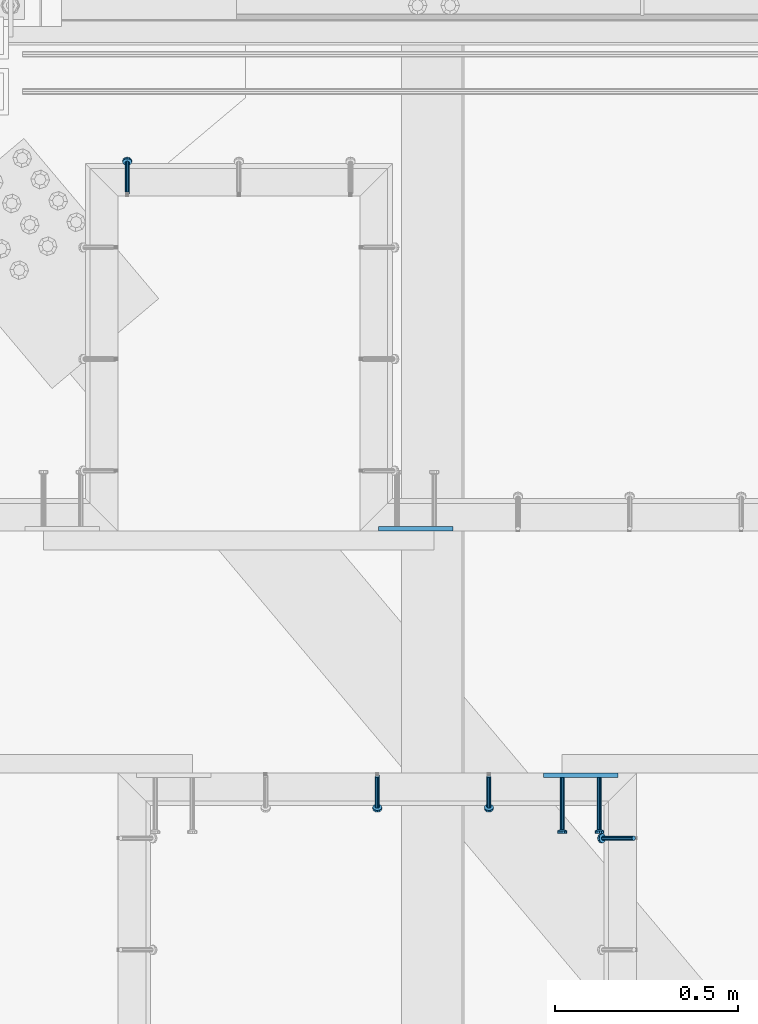
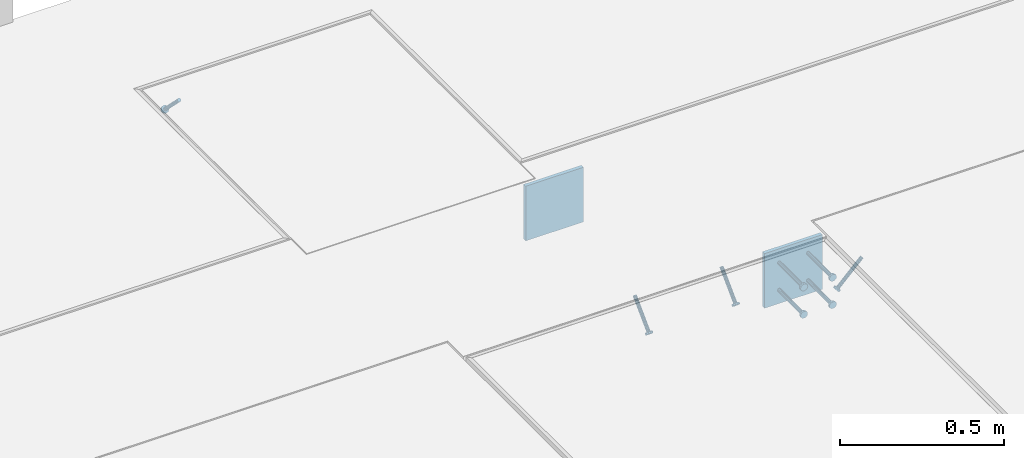
# One storey, part 2503 of 3843: 6 beams, 4 members, 5 elements without a shape of their own.
"""IFC2X3 building model written with IfcOpenShell, lengths in millimetres."""

import ifcopenshell
import ifcopenshell.guid

model = None  # the IFC model being written
_history = None  # IfcOwnerHistory: only IFC2X3 demands one
_inside = {}  # id of a spatial element -> (the spatial element, [elements in it])
_under = {}  # id of a project, library or spatial element -> (it, [spatial elements below it])
_declared = {}  # id of a project -> (the project, [libraries it declares])
_typed = {}  # id of a type object -> (the type object, [elements of that type])
_made_of = {}  # id of a material, layer set ... -> (it, [elements and type objects made of it])


def new_model(schema):
    """Start an empty IFC model of exactly this schema.

    Asked for "IFC4X3", IfcOpenShell would pick the latest addendum, in which some entities
    have other attributes; the version numbers below select the first issue.
    IFC2X3 requires an IfcOwnerHistory on every rooted entity: one is made here for all.
    """
    global model, _history
    if schema == "IFC4X3":
        model = ifcopenshell.file(schema_version=(4, 3, 0, 0))
    else:
        model = ifcopenshell.file(schema=schema)
    _inside.clear()
    _under.clear()
    _declared.clear()
    _typed.clear()
    _made_of.clear()
    _history = None
    if model.schema == "IFC2X3":
        org = make("IfcOrganization", Name="unknown")
        user = make(
            "IfcPersonAndOrganization",
            ThePerson=make("IfcPerson", FamilyName="unknown"),
            TheOrganization=org,
        )
        app = make(
            "IfcApplication",
            ApplicationDeveloper=org,
            Version="unknown",
            ApplicationFullName="unknown",
            ApplicationIdentifier="unknown",
        )
        _history = make(
            "IfcOwnerHistory",
            OwningUser=user,
            OwningApplication=app,
            ChangeAction="ADDED",
            CreationDate=0,
        )
    return model


def make(cls, **values):
    """One entity of the class cls with the attributes given. An attribute that is None is left unset."""
    return model.create_entity(
        cls, **{name: value for name, value in values.items() if value is not None}
    )


def rooted(cls, **values):
    """An entity with a GlobalId (a new one), such as an element, a storey or a relation."""
    return make(cls, GlobalId=ifcopenshell.guid.new(), OwnerHistory=_history, **values)


def si_unit(unit_type, name, prefix=None):
    """IfcSIUnit, for example si_unit("LENGTHUNIT", "METRE", prefix="MILLI")."""
    return make("IfcSIUnit", UnitType=unit_type, Prefix=prefix, Name=name)


def assignment(units):
    """IfcUnitAssignment: the units of a project."""
    return None if units is None else make("IfcUnitAssignment", Units=units)


def point(xyz):
    """IfcCartesianPoint."""
    return None if xyz is None else make("IfcCartesianPoint", Coordinates=xyz)


def direction(xyz):
    """IfcDirection."""
    return None if xyz is None else make("IfcDirection", DirectionRatios=xyz)


def frame(location, z_axis=None, x_axis=None):
    """IfcAxis2Placement3D, a coordinate frame: its origin and axes. An axis left out is left unset."""
    return make(
        "IfcAxis2Placement3D",
        Location=point(location),
        Axis=direction(z_axis),
        RefDirection=direction(x_axis),
    )


def origin_with_axes():
    """The frame at (0, 0, 0) with the z axis (0, 0, 1) and the x axis (1, 0, 0) written out."""
    return frame((0.0, 0.0, 0.0), z_axis=(0.0, 0.0, 1.0), x_axis=(1.0, 0.0, 0.0))


def place(relative_to, where):
    """IfcLocalPlacement: puts the frame where relative to a parent placement (None: the world)."""
    return make(
        "IfcLocalPlacement", PlacementRelTo=relative_to, RelativePlacement=where
    )


def context(
    kind, dimensions, precision=None, world=None, true_north=None, identifier=None
):
    """IfcGeometricRepresentationContext, for example the 3D "Model" context."""
    return make(
        "IfcGeometricRepresentationContext",
        ContextIdentifier=identifier,
        ContextType=kind,
        CoordinateSpaceDimension=dimensions,
        Precision=precision,
        WorldCoordinateSystem=world,
        TrueNorth=true_north,
    )


def subcontext(parent, identifier, kind, view, scale=None):
    """IfcGeometricRepresentationSubContext, for example "Body" below "Model"."""
    return make(
        "IfcGeometricRepresentationSubContext",
        ContextIdentifier=identifier,
        ContextType=kind,
        ParentContext=parent,
        TargetScale=scale,
        TargetView=view,
    )


def project(units=None, contexts=None):
    """IfcProject with its units and contexts."""
    return rooted(
        "IfcProject",
        Name="project",
        RepresentationContexts=contexts,
        UnitsInContext=assignment(units),
    )


def spatial(cls, under=None, at=None, **own):
    """A site, building, storey or space (cls), placed at a placement, below another one or the project."""
    s = rooted(cls, ObjectPlacement=at, **own)
    if under is not None:
        _under.setdefault(under.id(), (under, []))[1].append(s)
    return s


def faces_of(points, faces, orient=None, outer=None):
    """IfcFace entities. A face is a list of loops; a loop is a list of indices into points, from 0.

    orient and outer hold one flag for each loop. By default every Orientation is true, the
    first loop of a face is its IfcFaceOuterBound and the others are IfcFaceBound.
    """
    made = []
    for i, loops in enumerate(faces):
        bounds = []
        for j, loop in enumerate(loops):
            is_outer = j == 0 if outer is None else outer[i][j]
            bounds.append(
                make(
                    "IfcFaceOuterBound" if is_outer else "IfcFaceBound",
                    Bound=make("IfcPolyLoop", Polygon=[points[k] for k in loop]),
                    Orientation=True if orient is None else orient[i][j],
                )
            )
        made.append(make("IfcFace", Bounds=bounds))
    return made


def faceted_brep(points, faces, orient=None, outer=None, voids=None):
    """IfcFacetedBrep: a solid bounded by flat faces; with voids (closed shells), ...WithVoids."""
    shared = [point(p) for p in points]
    hull = make("IfcClosedShell", CfsFaces=faces_of(shared, faces, orient, outer))
    if voids is None:
        return make("IfcFacetedBrep", Outer=hull)
    return make(
        "IfcFacetedBrepWithVoids",
        Outer=hull,
        Voids=[
            make(cls, CfsFaces=faces_of(shared, fs, o, b)) for cls, fs, o, b in voids
        ],
    )


def shape(context_of_items, identifier, shape_type, items):
    """IfcShapeRepresentation: the items that make up one representation, for example the "Body"."""
    return make(
        "IfcShapeRepresentation",
        ContextOfItems=context_of_items,
        RepresentationIdentifier=identifier,
        RepresentationType=shape_type,
        Items=items,
    )


def material(Name=None, Category=None):
    """IfcMaterial."""
    return make("IfcMaterial", Name=Name, Category=Category)


def made_of(thing, what):
    """Note that an element or type object is made of a material, layer set ...; save() writes the relation."""
    if what is not None:
        _made_of.setdefault(what.id(), (what, []))[1].append(thing)
    return thing


def type_object(cls, material=None, **own):
    """A type object (cls), such as IfcWallType, which elements share."""
    return made_of(rooted(cls, **own), material)


def element(
    cls,
    number,
    at=None,
    inside=None,
    cuts=None,
    type_object=None,
    material=None,
    context=None,
    identifier="Body",
    shape_type=None,
    held_by="IfcProductDefinitionShape",
    body=None,
    shapes=None,
    **own,
):
    """One element of the class cls, such as IfcWall. Its Tag is "e" and its number.

    at: its placement. inside: the storey or other place that contains it. cuts: it is an
    opening in that element (IfcRelVoidsElement). A single representation is given by context,
    identifier, shape_type and body (its items); several are given by shapes. held_by: the class
    of the entity that holds the representations. save() writes the other relations.
    """
    e = rooted(cls, Tag="e%d" % number, ObjectPlacement=at, **own)
    if body is not None:
        shapes = [shape(context, identifier, shape_type, body)]
    if shapes is not None:
        e.Representation = make(held_by, Representations=shapes)
    if inside is not None:
        _inside.setdefault(inside.id(), (inside, []))[1].append(e)
    if cuts is not None:
        rooted(
            "IfcRelVoidsElement", RelatingBuildingElement=cuts, RelatedOpeningElement=e
        )
    if type_object is not None:
        _typed.setdefault(type_object.id(), (type_object, []))[1].append(e)
    return made_of(e, material)


def aggregate(whole, parts):
    """IfcRelAggregates: a whole, such as a stair, and the parts it consists of."""
    return rooted("IfcRelAggregates", RelatingObject=whole, RelatedObjects=parts)


def save(model, path):
    """Write the relations noted so far, then the file.

    IfcRelAggregates (storeys below a building ...), IfcRelContainedInSpatialStructure (elements
    in a storey), IfcRelDefinesByType, IfcRelAssociatesMaterial and IfcRelDeclares: one each for
    every whole, place, type object, material and project.
    """
    for whole, parts in _under.values():
        aggregate(whole, parts)
    for where, things in _inside.values():
        rooted(
            "IfcRelContainedInSpatialStructure",
            RelatedElements=things,
            RelatingStructure=where,
        )
    for kind, things in _typed.values():
        rooted("IfcRelDefinesByType", RelatedObjects=things, RelatingType=kind)
    for what, things in _made_of.values():
        rooted("IfcRelAssociatesMaterial", RelatedObjects=things, RelatingMaterial=what)
    for by, libraries in _declared.values():
        rooted("IfcRelDeclares", RelatingContext=by, RelatedDefinitions=libraries)
    model.write(path)


model = new_model("IFC2X3")

# Units and contexts
model_context = context("Model", 3, precision=1e-05, world=origin_with_axes())
body_context = subcontext(model_context, "Body", "Model", "MODEL_VIEW")
ifc_project = project(units=[si_unit("LENGTHUNIT", "METRE", prefix="MILLI"), si_unit("AREAUNIT", "SQUARE_METRE"), si_unit("VOLUMEUNIT", "CUBIC_METRE"), si_unit("MASSUNIT", "GRAM", prefix="KILO"), si_unit("TIMEUNIT", "SECOND"), si_unit("PLANEANGLEUNIT", "RADIAN"), si_unit("SOLIDANGLEUNIT", "STERADIAN"), si_unit("THERMODYNAMICTEMPERATUREUNIT", "DEGREE_CELSIUS"), si_unit("LUMINOUSINTENSITYUNIT", "LUMEN")], contexts=[model_context])

# Site, building, storey
site_placement = place(None, origin_with_axes())
site = spatial("IfcSite", under=ifc_project, at=site_placement, CompositionType="ELEMENT")
building_placement = place(site_placement, origin_with_axes())
building = spatial("IfcBuilding", under=site, at=building_placement, Name="Undefined", CompositionType="ELEMENT")
storey_placement = place(building_placement, origin_with_axes())
storey = spatial("IfcBuildingStorey", under=building, at=storey_placement, Name="Undefined", CompositionType="ELEMENT", Elevation=0.0)

# Assembly, member
assembly_1_placement = place(storey_placement, origin_with_axes())
assembly_1 = element("IfcElementAssembly", 1, at=assembly_1_placement, inside=storey, Name="EMBED_ANGLE", AssemblyPlace="NOTDEFINED", PredefinedType="RIGID_FRAME")
ifc_material_1 = material(Name="STEEL/A108")
member_type = type_object("IfcMemberType", PredefinedType="NOTDEFINED")
member_1_placement = place(assembly_1_placement, frame((49892.7001822153, 91631.9607012059, 30446.6625), z_axis=(-1.0, 0.0, 0.0), x_axis=(5.70000238222118e-08, 0.707106781186546, -0.707106781186546)))
member_1 = element("IfcMember", 2, at=member_1_placement, type_object=member_type, material=ifc_material_1, Name="HEADED STUD ANCHOR", context=body_context, shape_type="Brep", body=[
    faceted_brep([(7.27595761418343e-12, -3.18000006675175, 5.5), (0.0, -5.49999999998363, 3.1800000667572), (118.110000000976, -5.49999999999091, 3.1800000667572), (118.110000000983, -3.18000006675175, 5.5), (0.0, -6.3499999046162, 0.0), (118.110000000968, -6.34999990461256, 0.0), (0.0, -5.49999999998363, -3.1800000667572), (118.110000000976, -5.49999999999091, -3.1800000667572), (7.27595761418343e-12, -3.18000006675175, -5.5), (118.110000000983, -3.18000006675175, -5.5), (7.27595761418343e-12, -1.81898940354586e-12, -6.34999990463257), (118.110000000968, -1.81898940354586e-12, -6.34999990463257), (0.0, 3.18000006675175, -5.5), (118.110000000968, 3.18000006674811, -5.5), (7.27595761418343e-12, 5.49999999998363, -3.1800000667572), (118.110000000983, 5.49999999998363, -3.1800000667572), (7.27595761418343e-12, 6.3499999046162, 0.0), (118.110000000976, 6.34999990461256, 0.0), (7.27595761418343e-12, 5.49999999998363, 3.1800000667572), (118.110000000983, 5.49999999998363, 3.1800000667572), (0.0, 3.18000006675175, 5.5), (118.110000000968, 3.18000006674811, 5.5), (7.27595761418343e-12, -1.81898940354586e-12, 6.34999990463257), (118.110000000968, -1.81898940354586e-12, 6.34999990463257), (120.650000000991, -10.9899997710909, 6.34999990463257), (120.650000000998, -6.34000015257152, 10.9899997711182), (120.650000000991, -12.6999998092379, 0.0), (120.650000000991, -10.9899997710909, -6.34999990463257), (120.650000000998, -6.34000015257152, -10.9899997711182), (120.650000000991, -1.81898940354586e-12, -12.6899995803833), (120.650000000991, 6.34000015257152, -10.9899997711182), (120.650000000998, 10.9899997710909, -6.34999990463257), (120.650000000991, 12.6999998092342, 0.0), (120.650000000998, 10.9899997710909, 6.34999990463257), (120.650000000991, 6.34000015257152, 10.9899997711182), (120.650000000991, -1.81898940354586e-12, 12.6899995803833), (127.000000001048, -10.9899997710945, 6.34999990463257), (127.000000001048, -6.34000015257152, 10.9899997711182), (127.000000001048, -12.6999998092342, 0.0), (127.000000001048, -10.9899997710945, -6.34999990463257), (127.000000001048, -6.34000015257152, -10.9899997711182), (127.000000001048, 1.81898940354586e-12, -12.6899995803833), (127.000000001048, 6.34000015256788, -10.9899997711182), (127.000000001048, 10.9899997710909, -6.34999990463257), (127.000000001048, 12.6999998092379, 0.0), (127.000000001048, 10.9899997710909, 6.34999990463257), (127.000000001048, 6.34000015256788, 10.9899997711182), (127.000000001048, 1.81898940354586e-12, 12.6899995803833)], [[[0, 1, 2, 3]], [[1, 4, 5, 2]], [[4, 6, 7, 5]], [[6, 8, 9, 7]], [[8, 10, 11, 9]], [[10, 12, 13, 11]], [[12, 14, 15, 13]], [[14, 16, 17, 15]], [[16, 18, 19, 17]], [[18, 20, 21, 19]], [[20, 22, 23, 21]], [[22, 0, 3, 23]], [[22, 20, 18, 16, 14, 12, 10, 8, 6, 4, 1, 0]], [[3, 2, 24, 25]], [[2, 5, 26, 24]], [[5, 7, 27, 26]], [[7, 9, 28, 27]], [[9, 11, 29, 28]], [[11, 13, 30, 29]], [[13, 15, 31, 30]], [[15, 17, 32, 31]], [[17, 19, 33, 32]], [[19, 21, 34, 33]], [[21, 23, 35, 34]], [[23, 3, 25, 35]], [[25, 24, 36, 37]], [[24, 26, 38, 36]], [[26, 27, 39, 38]], [[27, 28, 40, 39]], [[28, 29, 41, 40]], [[29, 30, 42, 41]], [[30, 31, 43, 42]], [[31, 32, 44, 43]], [[32, 33, 45, 44]], [[33, 34, 46, 45]], [[34, 35, 47, 46]], [[35, 25, 37, 47]], [[38, 39, 40, 41, 42, 43, 44, 45, 46, 47, 37, 36]]]),
])
aggregate(assembly_1, [member_1])

# Assembly, members
assembly_2_placement = place(storey_placement, origin_with_axes())
assembly_2 = element("IfcElementAssembly", 3, at=assembly_2_placement, inside=storey, Name="EMBED_ANGLE", AssemblyPlace="NOTDEFINED", PredefinedType="RIGID_FRAME")
member_2_placement = place(assembly_2_placement, frame((50880.1503329119, 90041.285203125, 30446.6625), z_axis=(-1.0, 0.0, 0.0), x_axis=(0.0, -0.707106781186548, -0.707106781186548)))
member_2 = element("IfcMember", 4, at=member_2_placement, type_object=member_type, material=ifc_material_1, Name="HEADED STUD ANCHOR", context=body_context, shape_type="Brep", body=[
    faceted_brep([(7.27595761418343e-12, -3.18000006675175, 5.5), (0.0, -5.49999999998363, 3.1800000667572), (118.110000000976, -5.49999999999091, 3.1800000667572), (118.110000000983, -3.18000006675175, 5.5), (0.0, -6.3499999046162, 0.0), (118.110000000968, -6.34999990461256, 0.0), (0.0, -5.49999999998363, -3.1800000667572), (118.110000000976, -5.49999999999091, -3.1800000667572), (7.27595761418343e-12, -3.18000006675175, -5.5), (118.110000000983, -3.18000006675175, -5.5), (7.27595761418343e-12, -1.81898940354586e-12, -6.34999990463257), (118.110000000968, -1.81898940354586e-12, -6.34999990463257), (0.0, 3.18000006675175, -5.5), (118.110000000968, 3.18000006674811, -5.5), (7.27595761418343e-12, 5.49999999998363, -3.1800000667572), (118.110000000983, 5.49999999998363, -3.1800000667572), (7.27595761418343e-12, 6.3499999046162, 0.0), (118.110000000976, 6.34999990461256, 0.0), (7.27595761418343e-12, 5.49999999998363, 3.1800000667572), (118.110000000983, 5.49999999998363, 3.1800000667572), (0.0, 3.18000006675175, 5.5), (118.110000000968, 3.18000006674811, 5.5), (7.27595761418343e-12, -1.81898940354586e-12, 6.34999990463257), (118.110000000968, -1.81898940354586e-12, 6.34999990463257), (120.650000000991, -10.9899997710909, 6.34999990463257), (120.650000000998, -6.34000015257152, 10.9899997711182), (120.650000000991, -12.6999998092379, 0.0), (120.650000000991, -10.9899997710909, -6.34999990463257), (120.650000000998, -6.34000015257152, -10.9899997711182), (120.650000000991, -1.81898940354586e-12, -12.6899995803833), (120.650000000991, 6.34000015257152, -10.9899997711182), (120.650000000998, 10.9899997710909, -6.34999990463257), (120.650000000991, 12.6999998092342, 0.0), (120.650000000998, 10.9899997710909, 6.34999990463257), (120.650000000991, 6.34000015257152, 10.9899997711182), (120.650000000991, -1.81898940354586e-12, 12.6899995803833), (127.000000001048, -10.9899997710945, 6.34999990463257), (127.000000001048, -6.34000015257152, 10.9899997711182), (127.000000001048, -12.6999998092342, 0.0), (127.000000001048, -10.9899997710945, -6.34999990463257), (127.000000001048, -6.34000015257152, -10.9899997711182), (127.000000001048, 1.81898940354586e-12, -12.6899995803833), (127.000000001048, 6.34000015256788, -10.9899997711182), (127.000000001048, 10.9899997710909, -6.34999990463257), (127.000000001048, 12.6999998092379, 0.0), (127.000000001048, 10.9899997710909, 6.34999990463257), (127.000000001048, 6.34000015256788, 10.9899997711182), (127.000000001048, 1.81898940354586e-12, 12.6899995803833)], [[[0, 1, 2, 3]], [[1, 4, 5, 2]], [[4, 6, 7, 5]], [[6, 8, 9, 7]], [[8, 10, 11, 9]], [[10, 12, 13, 11]], [[12, 14, 15, 13]], [[14, 16, 17, 15]], [[16, 18, 19, 17]], [[18, 20, 21, 19]], [[20, 22, 23, 21]], [[22, 0, 3, 23]], [[22, 20, 18, 16, 14, 12, 10, 8, 6, 4, 1, 0]], [[3, 2, 24, 25]], [[2, 5, 26, 24]], [[5, 7, 27, 26]], [[7, 9, 28, 27]], [[9, 11, 29, 28]], [[11, 13, 30, 29]], [[13, 15, 31, 30]], [[15, 17, 32, 31]], [[17, 19, 33, 32]], [[19, 21, 34, 33]], [[21, 23, 35, 34]], [[23, 3, 25, 35]], [[25, 24, 36, 37]], [[24, 26, 38, 36]], [[26, 27, 39, 38]], [[27, 28, 40, 39]], [[28, 29, 41, 40]], [[29, 30, 42, 41]], [[30, 31, 43, 42]], [[31, 32, 44, 43]], [[32, 33, 45, 44]], [[33, 34, 46, 45]], [[34, 35, 47, 46]], [[35, 25, 37, 47]], [[38, 39, 40, 41, 42, 43, 44, 45, 46, 47, 37, 36]]]),
])
member_3_placement = place(assembly_2_placement, frame((50575.3503329119, 90041.285203125, 30446.6625), z_axis=(-1.0, 0.0, 0.0), x_axis=(0.0, -0.707106781186548, -0.707106781186548)))
member_3 = element("IfcMember", 5, at=member_3_placement, type_object=member_type, material=ifc_material_1, Name="HEADED STUD ANCHOR", context=body_context, shape_type="Brep", body=[
    faceted_brep([(7.27595761418343e-12, -3.18000006675175, 5.5), (0.0, -5.49999999998363, 3.1800000667572), (118.110000000976, -5.49999999999091, 3.1800000667572), (118.110000000983, -3.18000006675175, 5.5), (0.0, -6.3499999046162, 0.0), (118.110000000968, -6.34999990461256, 0.0), (0.0, -5.49999999998363, -3.1800000667572), (118.110000000976, -5.49999999999091, -3.1800000667572), (7.27595761418343e-12, -3.18000006675175, -5.5), (118.110000000983, -3.18000006675175, -5.5), (7.27595761418343e-12, -1.81898940354586e-12, -6.34999990463257), (118.110000000968, -1.81898940354586e-12, -6.34999990463257), (0.0, 3.18000006675175, -5.5), (118.110000000968, 3.18000006674811, -5.5), (7.27595761418343e-12, 5.49999999998363, -3.1800000667572), (118.110000000983, 5.49999999998363, -3.1800000667572), (7.27595761418343e-12, 6.3499999046162, 0.0), (118.110000000976, 6.34999990461256, 0.0), (7.27595761418343e-12, 5.49999999998363, 3.1800000667572), (118.110000000983, 5.49999999998363, 3.1800000667572), (0.0, 3.18000006675175, 5.5), (118.110000000968, 3.18000006674811, 5.5), (7.27595761418343e-12, -1.81898940354586e-12, 6.34999990463257), (118.110000000968, -1.81898940354586e-12, 6.34999990463257), (120.650000000991, -10.9899997710909, 6.34999990463257), (120.650000000998, -6.34000015257152, 10.9899997711182), (120.650000000991, -12.6999998092379, 0.0), (120.650000000991, -10.9899997710909, -6.34999990463257), (120.650000000998, -6.34000015257152, -10.9899997711182), (120.650000000991, -1.81898940354586e-12, -12.6899995803833), (120.650000000991, 6.34000015257152, -10.9899997711182), (120.650000000998, 10.9899997710909, -6.34999990463257), (120.650000000991, 12.6999998092342, 0.0), (120.650000000998, 10.9899997710909, 6.34999990463257), (120.650000000991, 6.34000015257152, 10.9899997711182), (120.650000000991, -1.81898940354586e-12, 12.6899995803833), (127.000000001048, -10.9899997710945, 6.34999990463257), (127.000000001048, -6.34000015257152, 10.9899997711182), (127.000000001048, -12.6999998092342, 0.0), (127.000000001048, -10.9899997710945, -6.34999990463257), (127.000000001048, -6.34000015257152, -10.9899997711182), (127.000000001048, 1.81898940354586e-12, -12.6899995803833), (127.000000001048, 6.34000015256788, -10.9899997711182), (127.000000001048, 10.9899997710909, -6.34999990463257), (127.000000001048, 12.6999998092379, 0.0), (127.000000001048, 10.9899997710909, 6.34999990463257), (127.000000001048, 6.34000015256788, 10.9899997711182), (127.000000001048, 1.81898940354586e-12, 12.6899995803833)], [[[0, 1, 2, 3]], [[1, 4, 5, 2]], [[4, 6, 7, 5]], [[6, 8, 9, 7]], [[8, 10, 11, 9]], [[10, 12, 13, 11]], [[12, 14, 15, 13]], [[14, 16, 17, 15]], [[16, 18, 19, 17]], [[18, 20, 21, 19]], [[20, 22, 23, 21]], [[22, 0, 3, 23]], [[22, 20, 18, 16, 14, 12, 10, 8, 6, 4, 1, 0]], [[3, 2, 24, 25]], [[2, 5, 26, 24]], [[5, 7, 27, 26]], [[7, 9, 28, 27]], [[9, 11, 29, 28]], [[11, 13, 30, 29]], [[13, 15, 31, 30]], [[15, 17, 32, 31]], [[17, 19, 33, 32]], [[19, 21, 34, 33]], [[21, 23, 35, 34]], [[23, 3, 25, 35]], [[25, 24, 36, 37]], [[24, 26, 38, 36]], [[26, 27, 39, 38]], [[27, 28, 40, 39]], [[28, 29, 41, 40]], [[29, 30, 42, 41]], [[30, 31, 43, 42]], [[31, 32, 44, 43]], [[32, 33, 45, 44]], [[33, 34, 46, 45]], [[34, 35, 47, 46]], [[35, 25, 37, 47]], [[38, 39, 40, 41, 42, 43, 44, 45, 46, 47, 37, 36]]]),
])
aggregate(assembly_2, [member_2, member_3])

# Assembly, member
assembly_3_placement = place(storey_placement, origin_with_axes())
assembly_3 = element("IfcElementAssembly", 6, at=assembly_3_placement, inside=storey, Name="EMBED_ANGLE", AssemblyPlace="NOTDEFINED", PredefinedType="RIGID_FRAME")
member_4_placement = place(assembly_3_placement, frame((51275.4879423829, 89871.4227092285, 30446.6625), z_axis=(0.0, 1.0, 0.0), x_axis=(-0.707106781186548, 0.0, -0.707106781186548)))
member_4 = element("IfcMember", 7, at=member_4_placement, type_object=member_type, material=ifc_material_1, Name="HEADED STUD ANCHOR", context=body_context, shape_type="Brep", body=[
    faceted_brep([(7.27595761418343e-12, -3.18000006675175, 5.5), (0.0, -5.49999999998363, 3.1800000667572), (118.110000000976, -5.49999999999091, 3.1800000667572), (118.110000000983, -3.18000006675175, 5.5), (0.0, -6.3499999046162, 0.0), (118.110000000968, -6.34999990461256, 0.0), (0.0, -5.49999999998363, -3.1800000667572), (118.110000000976, -5.49999999999091, -3.1800000667572), (7.27595761418343e-12, -3.18000006675175, -5.5), (118.110000000983, -3.18000006675175, -5.5), (7.27595761418343e-12, -1.81898940354586e-12, -6.34999990463257), (118.110000000968, -1.81898940354586e-12, -6.34999990463257), (0.0, 3.18000006675175, -5.5), (118.110000000968, 3.18000006674811, -5.5), (7.27595761418343e-12, 5.49999999998363, -3.1800000667572), (118.110000000983, 5.49999999998363, -3.1800000667572), (7.27595761418343e-12, 6.3499999046162, 0.0), (118.110000000976, 6.34999990461256, 0.0), (7.27595761418343e-12, 5.49999999998363, 3.1800000667572), (118.110000000983, 5.49999999998363, 3.1800000667572), (0.0, 3.18000006675175, 5.5), (118.110000000968, 3.18000006674811, 5.5), (7.27595761418343e-12, -1.81898940354586e-12, 6.34999990463257), (118.110000000968, -1.81898940354586e-12, 6.34999990463257), (120.650000000991, -10.9899997710909, 6.34999990463257), (120.650000000998, -6.34000015257152, 10.9899997711182), (120.650000000991, -12.6999998092379, 0.0), (120.650000000991, -10.9899997710909, -6.34999990463257), (120.650000000998, -6.34000015257152, -10.9899997711182), (120.650000000991, -1.81898940354586e-12, -12.6899995803833), (120.650000000991, 6.34000015257152, -10.9899997711182), (120.650000000998, 10.9899997710909, -6.34999990463257), (120.650000000991, 12.6999998092342, 0.0), (120.650000000998, 10.9899997710909, 6.34999990463257), (120.650000000991, 6.34000015257152, 10.9899997711182), (120.650000000991, -1.81898940354586e-12, 12.6899995803833), (127.000000001048, -10.9899997710945, 6.34999990463257), (127.000000001048, -6.34000015257152, 10.9899997711182), (127.000000001048, -12.6999998092342, 0.0), (127.000000001048, -10.9899997710945, -6.34999990463257), (127.000000001048, -6.34000015257152, -10.9899997711182), (127.000000001048, 1.81898940354586e-12, -12.6899995803833), (127.000000001048, 6.34000015256788, -10.9899997711182), (127.000000001048, 10.9899997710909, -6.34999990463257), (127.000000001048, 12.6999998092379, 0.0), (127.000000001048, 10.9899997710909, 6.34999990463257), (127.000000001048, 6.34000015256788, 10.9899997711182), (127.000000001048, 1.81898940354586e-12, 12.6899995803833)], [[[0, 1, 2, 3]], [[1, 4, 5, 2]], [[4, 6, 7, 5]], [[6, 8, 9, 7]], [[8, 10, 11, 9]], [[10, 12, 13, 11]], [[12, 14, 15, 13]], [[14, 16, 17, 15]], [[16, 18, 19, 17]], [[18, 20, 21, 19]], [[20, 22, 23, 21]], [[22, 0, 3, 23]], [[22, 20, 18, 16, 14, 12, 10, 8, 6, 4, 1, 0]], [[3, 2, 24, 25]], [[2, 5, 26, 24]], [[5, 7, 27, 26]], [[7, 9, 28, 27]], [[9, 11, 29, 28]], [[11, 13, 30, 29]], [[13, 15, 31, 30]], [[15, 17, 32, 31]], [[17, 19, 33, 32]], [[19, 21, 34, 33]], [[21, 23, 35, 34]], [[23, 3, 25, 35]], [[25, 24, 36, 37]], [[24, 26, 38, 36]], [[26, 27, 39, 38]], [[27, 28, 40, 39]], [[28, 29, 41, 40]], [[29, 30, 42, 41]], [[30, 31, 43, 42]], [[31, 32, 44, 43]], [[32, 33, 45, 44]], [[33, 34, 46, 45]], [[34, 35, 47, 46]], [[35, 25, 37, 47]], [[38, 39, 40, 41, 42, 43, 44, 45, 46, 47, 37, 36]]]),
])
aggregate(assembly_3, [member_4])

# Assembly, beam
assembly_4_placement = place(storey_placement, origin_with_axes())
assembly_4 = element("IfcElementAssembly", 8, at=assembly_4_placement, inside=storey, Name="EMBED PLATE", AssemblyPlace="NOTDEFINED", PredefinedType="RIGID_FRAME")
ifc_material_2 = material(Name="STEEL/A36")
beam_type_1 = type_object("IfcBeamType", PredefinedType="NOTDEFINED")
beam_1_placement = place(assembly_4_placement, frame((51130.9886082177, 90042.8731429479, 30445.075), z_axis=(-1.0, 0.0, 0.0), x_axis=(0.0, 0.0, -1.0)))
beam_1 = element("IfcBeam", 9, at=beam_1_placement, type_object=beam_type_1, material=ifc_material_2, Name="EMBED PLATE", context=body_context, shape_type="Brep", body=[
    faceted_brep([(1.74622982740402e-10, 6.35000000000582, -101.600000000195), (-1.67347025126219e-10, 6.35000000000582, 101.600000000151), (203.200000000001, 6.35000000000582, 101.599999999999), (203.200000000001, 6.35000000000582, -101.599999999999), (-1.67347025126219e-10, -6.35000000000582, 101.600000000151), (203.200000000001, -6.35000000000582, 101.599999999999), (1.74622982740402e-10, -6.35000000000582, -101.600000000195), (203.200000000001, -6.35000000000582, -101.599999999999)], [[[0, 1, 2, 3]], [[1, 4, 5, 2]], [[4, 6, 7, 5]], [[6, 0, 3, 7]], [[5, 7, 3, 2]], [[6, 4, 1, 0]]]),
])

assembly_5_placement = place(storey_placement, origin_with_axes())
assembly_5 = element("IfcElementAssembly", 10, at=assembly_5_placement, inside=storey, Name="EMBED PLATE", AssemblyPlace="NOTDEFINED", PredefinedType="RIGID_FRAME")
beam_2_placement = place(assembly_5_placement, frame((50680.1121552734, 90715.9730224609, 30445.075), z_axis=(1.0, 0.0, 0.0), x_axis=(0.0, 0.0, -1.0)))
beam_2 = element("IfcBeam", 11, at=beam_2_placement, type_object=beam_type_1, material=ifc_material_2, Name="EMBED PLATE", context=body_context, shape_type="Brep", body=[
    faceted_brep([(1.74622982740402e-10, 6.35000000000582, -101.600000000195), (-1.67347025126219e-10, 6.35000000000582, 101.600000000151), (203.200000000001, 6.35000000000582, 101.599999999999), (203.200000000001, 6.35000000000582, -101.599999999999), (-1.67347025126219e-10, -6.35000000000582, 101.600000000151), (203.200000000001, -6.35000000000582, 101.599999999999), (1.74622982740402e-10, -6.35000000000582, -101.600000000195), (203.200000000001, -6.35000000000582, -101.599999999999)], [[[0, 1, 2, 3]], [[1, 4, 5, 2]], [[4, 6, 7, 5]], [[6, 0, 3, 7]], [[5, 7, 3, 2]], [[6, 4, 1, 0]]]),
])
aggregate(assembly_5, [beam_2])

# Beam
beam_type_2 = type_object("IfcBeamType", PredefinedType="NOTDEFINED")
beam_3_placement = place(assembly_4_placement, frame((51181.7886082177, 90036.5231429479, 30394.275), z_axis=(1.0, 0.0, 0.0), x_axis=(0.0, -1.0, 0.0)))
beam_3 = element("IfcBeam", 12, at=beam_3_placement, type_object=beam_type_2, material=ifc_material_1, Name="HEADED STUD ANCHOR", context=body_context, shape_type="Brep", body=[
    faceted_brep([(7.27595761418343e-12, -3.18000006675175, 5.5), (0.0, -5.49999999998363, 3.1800000667572), (141.731999999989, -5.5, 3.1800000667572), (141.731999999989, -3.1800000667572, 5.5), (0.0, -6.3499999046162, 0.0), (141.731999999989, -6.34999990463257, 0.0), (0.0, -5.49999999998363, -3.1800000667572), (141.731999999989, -5.5, -3.1800000667572), (7.27595761418343e-12, -3.18000006675175, -5.5), (141.731999999989, -3.1800000667572, -5.5), (7.27595761418343e-12, -1.81898940354586e-12, -6.34999990463257), (141.731999999989, 0.0, -6.34999990463257), (0.0, 3.18000006675175, -5.5), (141.731999999989, 3.1800000667572, -5.5), (7.27595761418343e-12, 5.49999999998363, -3.1800000667572), (141.731999999989, 5.5, -3.1800000667572), (7.27595761418343e-12, 6.3499999046162, 0.0), (141.731999999989, 6.34999990463257, 0.0), (7.27595761418343e-12, 5.49999999998363, 3.1800000667572), (141.731999999989, 5.5, 3.1800000667572), (0.0, 3.18000006675175, 5.5), (141.731999999989, 3.1800000667572, 5.5), (7.27595761418343e-12, -1.81898940354586e-12, 6.34999990463257), (141.731999999989, 0.0, 6.34999990463257), (144.779999999999, -10.9899997711182, 6.34999990463257), (144.779999999999, -6.34000015258789, 10.9899997711182), (144.779999999999, -12.6999998092651, 0.0), (144.779999999999, -10.9899997711182, -6.34999990463257), (144.779999999999, -6.34000015258789, -10.9899997711182), (144.779999999999, 0.0, -12.6899995803833), (144.779999999999, 6.34000015258789, -10.9899997711182), (144.779999999999, 10.9899997711182, -6.34999990463257), (144.779999999999, 12.6999998092651, 0.0), (144.779999999999, 10.9899997711182, 6.34999990463257), (144.779999999999, 6.34000015258789, 10.9899997711182), (144.779999999999, 0.0, 12.6899995803833), (152.399999999994, -10.9899997711182, 6.34999990463257), (152.399999999994, -6.34000015258789, 10.9899997711182), (152.399999999994, -12.6999998092651, 0.0), (152.399999999994, -10.9899997711182, -6.34999990463257), (152.399999999994, -6.34000015258789, -10.9899997711182), (152.399999999994, 0.0, -12.6899995803833), (152.399999999994, 6.34000015258789, -10.9899997711182), (152.399999999994, 10.9899997711182, -6.34999990463257), (152.399999999994, 12.6999998092651, 0.0), (152.399999999994, 10.9899997711182, 6.34999990463257), (152.399999999994, 6.34000015258789, 10.9899997711182), (152.399999999994, 0.0, 12.6899995803833)], [[[0, 1, 2, 3]], [[1, 4, 5, 2]], [[4, 6, 7, 5]], [[6, 8, 9, 7]], [[8, 10, 11, 9]], [[10, 12, 13, 11]], [[12, 14, 15, 13]], [[14, 16, 17, 15]], [[16, 18, 19, 17]], [[18, 20, 21, 19]], [[20, 22, 23, 21]], [[22, 0, 3, 23]], [[22, 20, 18, 16, 14, 12, 10, 8, 6, 4, 1, 0]], [[3, 2, 24, 25]], [[2, 5, 26, 24]], [[5, 7, 27, 26]], [[7, 9, 28, 27]], [[9, 11, 29, 28]], [[11, 13, 30, 29]], [[13, 15, 31, 30]], [[15, 17, 32, 31]], [[17, 19, 33, 32]], [[19, 21, 34, 33]], [[21, 23, 35, 34]], [[23, 3, 25, 35]], [[25, 24, 36, 37]], [[24, 26, 38, 36]], [[26, 27, 39, 38]], [[27, 28, 40, 39]], [[28, 29, 41, 40]], [[29, 30, 42, 41]], [[30, 31, 43, 42]], [[31, 32, 44, 43]], [[32, 33, 45, 44]], [[33, 34, 46, 45]], [[34, 35, 47, 46]], [[35, 25, 37, 47]], [[38, 39, 40, 41, 42, 43, 44, 45, 46, 47, 37, 36]]]),
])

beam_4_placement = place(assembly_4_placement, frame((51181.7886082177, 90036.5231429479, 30292.675), z_axis=(1.0, 0.0, 0.0), x_axis=(0.0, -1.0, 0.0)))
beam_4 = element("IfcBeam", 13, at=beam_4_placement, type_object=beam_type_2, material=ifc_material_1, Name="HEADED STUD ANCHOR", context=body_context, shape_type="Brep", body=[
    faceted_brep([(7.27595761418343e-12, -3.18000006675175, 5.5), (0.0, -5.49999999998363, 3.1800000667572), (141.731999999989, -5.5, 3.1800000667572), (141.731999999989, -3.1800000667572, 5.5), (0.0, -6.3499999046162, 0.0), (141.731999999989, -6.34999990463257, 0.0), (0.0, -5.49999999998363, -3.1800000667572), (141.731999999989, -5.5, -3.1800000667572), (7.27595761418343e-12, -3.18000006675175, -5.5), (141.731999999989, -3.1800000667572, -5.5), (7.27595761418343e-12, -1.81898940354586e-12, -6.34999990463257), (141.731999999989, 0.0, -6.34999990463257), (0.0, 3.18000006675175, -5.5), (141.731999999989, 3.1800000667572, -5.5), (7.27595761418343e-12, 5.49999999998363, -3.1800000667572), (141.731999999989, 5.5, -3.1800000667572), (7.27595761418343e-12, 6.3499999046162, 0.0), (141.731999999989, 6.34999990463257, 0.0), (7.27595761418343e-12, 5.49999999998363, 3.1800000667572), (141.731999999989, 5.5, 3.1800000667572), (0.0, 3.18000006675175, 5.5), (141.731999999989, 3.1800000667572, 5.5), (7.27595761418343e-12, -1.81898940354586e-12, 6.34999990463257), (141.731999999989, 0.0, 6.34999990463257), (144.779999999999, -10.9899997711182, 6.34999990463257), (144.779999999999, -6.34000015258789, 10.9899997711182), (144.779999999999, -12.6999998092651, 0.0), (144.779999999999, -10.9899997711182, -6.34999990463257), (144.779999999999, -6.34000015258789, -10.9899997711182), (144.779999999999, 0.0, -12.6899995803833), (144.779999999999, 6.34000015258789, -10.9899997711182), (144.779999999999, 10.9899997711182, -6.34999990463257), (144.779999999999, 12.6999998092651, 0.0), (144.779999999999, 10.9899997711182, 6.34999990463257), (144.779999999999, 6.34000015258789, 10.9899997711182), (144.779999999999, 0.0, 12.6899995803833), (152.399999999994, -10.9899997711182, 6.34999990463257), (152.399999999994, -6.34000015258789, 10.9899997711182), (152.399999999994, -12.6999998092651, 0.0), (152.399999999994, -10.9899997711182, -6.34999990463257), (152.399999999994, -6.34000015258789, -10.9899997711182), (152.399999999994, 0.0, -12.6899995803833), (152.399999999994, 6.34000015258789, -10.9899997711182), (152.399999999994, 10.9899997711182, -6.34999990463257), (152.399999999994, 12.6999998092651, 0.0), (152.399999999994, 10.9899997711182, 6.34999990463257), (152.399999999994, 6.34000015258789, 10.9899997711182), (152.399999999994, 0.0, 12.6899995803833)], [[[0, 1, 2, 3]], [[1, 4, 5, 2]], [[4, 6, 7, 5]], [[6, 8, 9, 7]], [[8, 10, 11, 9]], [[10, 12, 13, 11]], [[12, 14, 15, 13]], [[14, 16, 17, 15]], [[16, 18, 19, 17]], [[18, 20, 21, 19]], [[20, 22, 23, 21]], [[22, 0, 3, 23]], [[22, 20, 18, 16, 14, 12, 10, 8, 6, 4, 1, 0]], [[3, 2, 24, 25]], [[2, 5, 26, 24]], [[5, 7, 27, 26]], [[7, 9, 28, 27]], [[9, 11, 29, 28]], [[11, 13, 30, 29]], [[13, 15, 31, 30]], [[15, 17, 32, 31]], [[17, 19, 33, 32]], [[19, 21, 34, 33]], [[21, 23, 35, 34]], [[23, 3, 25, 35]], [[25, 24, 36, 37]], [[24, 26, 38, 36]], [[26, 27, 39, 38]], [[27, 28, 40, 39]], [[28, 29, 41, 40]], [[29, 30, 42, 41]], [[30, 31, 43, 42]], [[31, 32, 44, 43]], [[32, 33, 45, 44]], [[33, 34, 46, 45]], [[34, 35, 47, 46]], [[35, 25, 37, 47]], [[38, 39, 40, 41, 42, 43, 44, 45, 46, 47, 37, 36]]]),
])

beam_5_placement = place(assembly_4_placement, frame((51080.1886082178, 90036.5231429479, 30394.275), z_axis=(1.0, 0.0, 0.0), x_axis=(0.0, -1.0, 0.0)))
beam_5 = element("IfcBeam", 14, at=beam_5_placement, type_object=beam_type_2, material=ifc_material_1, Name="HEADED STUD ANCHOR", context=body_context, shape_type="Brep", body=[
    faceted_brep([(7.27595761418343e-12, -3.18000006675175, 5.5), (0.0, -5.49999999998363, 3.1800000667572), (141.731999999989, -5.5, 3.1800000667572), (141.731999999989, -3.1800000667572, 5.5), (0.0, -6.3499999046162, 0.0), (141.731999999989, -6.34999990463257, 0.0), (0.0, -5.49999999998363, -3.1800000667572), (141.731999999989, -5.5, -3.1800000667572), (7.27595761418343e-12, -3.18000006675175, -5.5), (141.731999999989, -3.1800000667572, -5.5), (7.27595761418343e-12, -1.81898940354586e-12, -6.34999990463257), (141.731999999989, 0.0, -6.34999990463257), (0.0, 3.18000006675175, -5.5), (141.731999999989, 3.1800000667572, -5.5), (7.27595761418343e-12, 5.49999999998363, -3.1800000667572), (141.731999999989, 5.5, -3.1800000667572), (7.27595761418343e-12, 6.3499999046162, 0.0), (141.731999999989, 6.34999990463257, 0.0), (7.27595761418343e-12, 5.49999999998363, 3.1800000667572), (141.731999999989, 5.5, 3.1800000667572), (0.0, 3.18000006675175, 5.5), (141.731999999989, 3.1800000667572, 5.5), (7.27595761418343e-12, -1.81898940354586e-12, 6.34999990463257), (141.731999999989, 0.0, 6.34999990463257), (144.779999999999, -10.9899997711182, 6.34999990463257), (144.779999999999, -6.34000015258789, 10.9899997711182), (144.779999999999, -12.6999998092651, 0.0), (144.779999999999, -10.9899997711182, -6.34999990463257), (144.779999999999, -6.34000015258789, -10.9899997711182), (144.779999999999, 0.0, -12.6899995803833), (144.779999999999, 6.34000015258789, -10.9899997711182), (144.779999999999, 10.9899997711182, -6.34999990463257), (144.779999999999, 12.6999998092651, 0.0), (144.779999999999, 10.9899997711182, 6.34999990463257), (144.779999999999, 6.34000015258789, 10.9899997711182), (144.779999999999, 0.0, 12.6899995803833), (152.399999999994, -10.9899997711182, 6.34999990463257), (152.399999999994, -6.34000015258789, 10.9899997711182), (152.399999999994, -12.6999998092651, 0.0), (152.399999999994, -10.9899997711182, -6.34999990463257), (152.399999999994, -6.34000015258789, -10.9899997711182), (152.399999999994, 0.0, -12.6899995803833), (152.399999999994, 6.34000015258789, -10.9899997711182), (152.399999999994, 10.9899997711182, -6.34999990463257), (152.399999999994, 12.6999998092651, 0.0), (152.399999999994, 10.9899997711182, 6.34999990463257), (152.399999999994, 6.34000015258789, 10.9899997711182), (152.399999999994, 0.0, 12.6899995803833)], [[[0, 1, 2, 3]], [[1, 4, 5, 2]], [[4, 6, 7, 5]], [[6, 8, 9, 7]], [[8, 10, 11, 9]], [[10, 12, 13, 11]], [[12, 14, 15, 13]], [[14, 16, 17, 15]], [[16, 18, 19, 17]], [[18, 20, 21, 19]], [[20, 22, 23, 21]], [[22, 0, 3, 23]], [[22, 20, 18, 16, 14, 12, 10, 8, 6, 4, 1, 0]], [[3, 2, 24, 25]], [[2, 5, 26, 24]], [[5, 7, 27, 26]], [[7, 9, 28, 27]], [[9, 11, 29, 28]], [[11, 13, 30, 29]], [[13, 15, 31, 30]], [[15, 17, 32, 31]], [[17, 19, 33, 32]], [[19, 21, 34, 33]], [[21, 23, 35, 34]], [[23, 3, 25, 35]], [[25, 24, 36, 37]], [[24, 26, 38, 36]], [[26, 27, 39, 38]], [[27, 28, 40, 39]], [[28, 29, 41, 40]], [[29, 30, 42, 41]], [[30, 31, 43, 42]], [[31, 32, 44, 43]], [[32, 33, 45, 44]], [[33, 34, 46, 45]], [[34, 35, 47, 46]], [[35, 25, 37, 47]], [[38, 39, 40, 41, 42, 43, 44, 45, 46, 47, 37, 36]]]),
])

beam_6_placement = place(assembly_4_placement, frame((51080.1886082178, 90036.5231429479, 30292.675), z_axis=(1.0, 0.0, 0.0), x_axis=(0.0, -1.0, 0.0)))
beam_6 = element("IfcBeam", 15, at=beam_6_placement, type_object=beam_type_2, material=ifc_material_1, Name="HEADED STUD ANCHOR", context=body_context, shape_type="Brep", body=[
    faceted_brep([(7.27595761418343e-12, -3.18000006675175, 5.5), (0.0, -5.49999999998363, 3.1800000667572), (141.731999999989, -5.5, 3.1800000667572), (141.731999999989, -3.1800000667572, 5.5), (0.0, -6.3499999046162, 0.0), (141.731999999989, -6.34999990463257, 0.0), (0.0, -5.49999999998363, -3.1800000667572), (141.731999999989, -5.5, -3.1800000667572), (7.27595761418343e-12, -3.18000006675175, -5.5), (141.731999999989, -3.1800000667572, -5.5), (7.27595761418343e-12, -1.81898940354586e-12, -6.34999990463257), (141.731999999989, 0.0, -6.34999990463257), (0.0, 3.18000006675175, -5.5), (141.731999999989, 3.1800000667572, -5.5), (7.27595761418343e-12, 5.49999999998363, -3.1800000667572), (141.731999999989, 5.5, -3.1800000667572), (7.27595761418343e-12, 6.3499999046162, 0.0), (141.731999999989, 6.34999990463257, 0.0), (7.27595761418343e-12, 5.49999999998363, 3.1800000667572), (141.731999999989, 5.5, 3.1800000667572), (0.0, 3.18000006675175, 5.5), (141.731999999989, 3.1800000667572, 5.5), (7.27595761418343e-12, -1.81898940354586e-12, 6.34999990463257), (141.731999999989, 0.0, 6.34999990463257), (144.779999999999, -10.9899997711182, 6.34999990463257), (144.779999999999, -6.34000015258789, 10.9899997711182), (144.779999999999, -12.6999998092651, 0.0), (144.779999999999, -10.9899997711182, -6.34999990463257), (144.779999999999, -6.34000015258789, -10.9899997711182), (144.779999999999, 0.0, -12.6899995803833), (144.779999999999, 6.34000015258789, -10.9899997711182), (144.779999999999, 10.9899997711182, -6.34999990463257), (144.779999999999, 12.6999998092651, 0.0), (144.779999999999, 10.9899997711182, 6.34999990463257), (144.779999999999, 6.34000015258789, 10.9899997711182), (144.779999999999, 0.0, 12.6899995803833), (152.399999999994, -10.9899997711182, 6.34999990463257), (152.399999999994, -6.34000015258789, 10.9899997711182), (152.399999999994, -12.6999998092651, 0.0), (152.399999999994, -10.9899997711182, -6.34999990463257), (152.399999999994, -6.34000015258789, -10.9899997711182), (152.399999999994, 0.0, -12.6899995803833), (152.399999999994, 6.34000015258789, -10.9899997711182), (152.399999999994, 10.9899997711182, -6.34999990463257), (152.399999999994, 12.6999998092651, 0.0), (152.399999999994, 10.9899997711182, 6.34999990463257), (152.399999999994, 6.34000015258789, 10.9899997711182), (152.399999999994, 0.0, 12.6899995803833)], [[[0, 1, 2, 3]], [[1, 4, 5, 2]], [[4, 6, 7, 5]], [[6, 8, 9, 7]], [[8, 10, 11, 9]], [[10, 12, 13, 11]], [[12, 14, 15, 13]], [[14, 16, 17, 15]], [[16, 18, 19, 17]], [[18, 20, 21, 19]], [[20, 22, 23, 21]], [[22, 0, 3, 23]], [[22, 20, 18, 16, 14, 12, 10, 8, 6, 4, 1, 0]], [[3, 2, 24, 25]], [[2, 5, 26, 24]], [[5, 7, 27, 26]], [[7, 9, 28, 27]], [[9, 11, 29, 28]], [[11, 13, 30, 29]], [[13, 15, 31, 30]], [[15, 17, 32, 31]], [[17, 19, 33, 32]], [[19, 21, 34, 33]], [[21, 23, 35, 34]], [[23, 3, 25, 35]], [[25, 24, 36, 37]], [[24, 26, 38, 36]], [[26, 27, 39, 38]], [[27, 28, 40, 39]], [[28, 29, 41, 40]], [[29, 30, 42, 41]], [[30, 31, 43, 42]], [[31, 32, 44, 43]], [[32, 33, 45, 44]], [[33, 34, 46, 45]], [[34, 35, 47, 46]], [[35, 25, 37, 47]], [[38, 39, 40, 41, 42, 43, 44, 45, 46, 47, 37, 36]]]),
])

aggregate(assembly_4, [beam_3, beam_4, beam_5, beam_6, beam_1])

save(model, "model.ifc")
